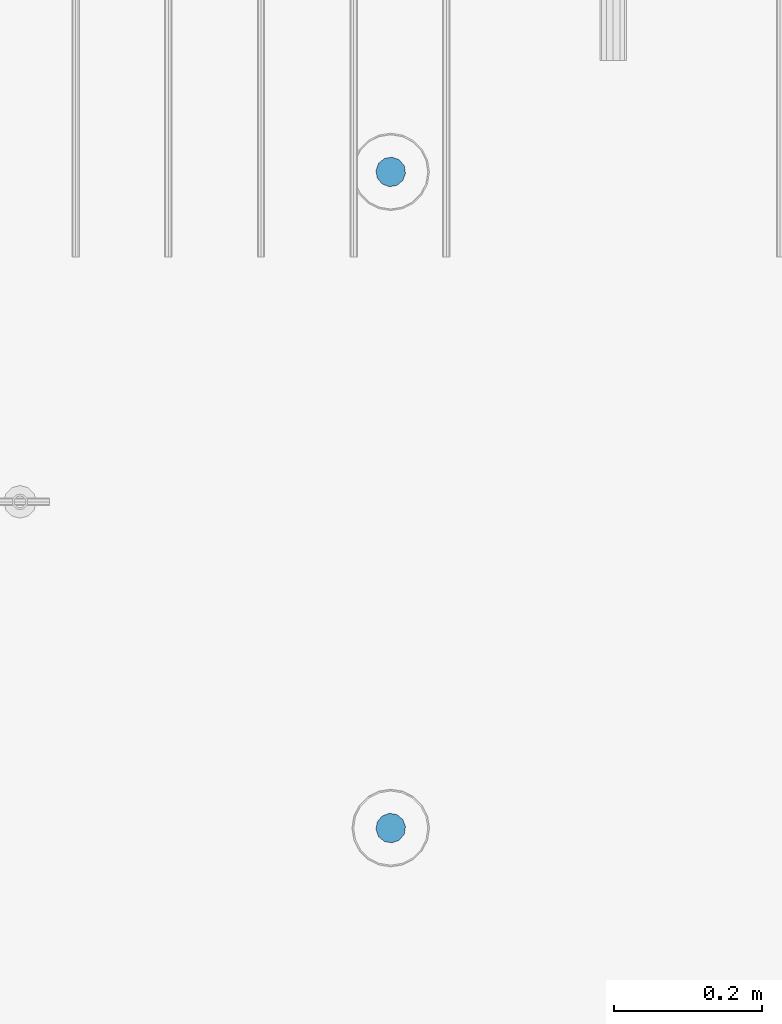
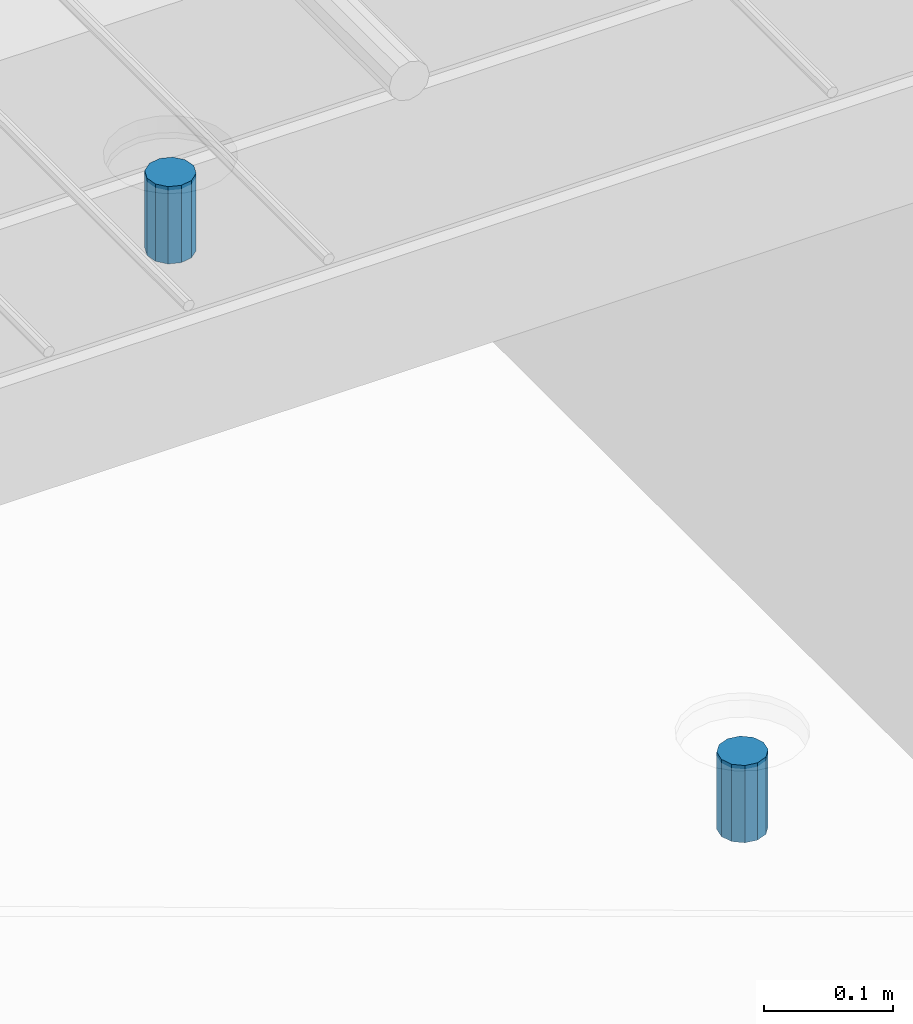
# One storey, part 50 of 350: 2 columns, 3 elements without a shape of their own.
"""IFC2X3 building model written with IfcOpenShell, lengths in millimetres."""

from ifc_helpers import new_model, si_unit, frame, origin_with_axes, place, context, subcontext, project, spatial, faceted_brep, material, type_object, element, aggregate, save


model = new_model("IFC2X3")

# Units and contexts
model_context = context("Model", 3, precision=1e-05, world=origin_with_axes())
body_context = subcontext(model_context, "Body", "Model", "MODEL_VIEW")
ifc_project = project(units=[si_unit("LENGTHUNIT", "METRE", prefix="MILLI"), si_unit("AREAUNIT", "SQUARE_METRE"), si_unit("VOLUMEUNIT", "CUBIC_METRE"), si_unit("MASSUNIT", "GRAM", prefix="KILO"), si_unit("TIMEUNIT", "SECOND"), si_unit("PLANEANGLEUNIT", "RADIAN"), si_unit("SOLIDANGLEUNIT", "STERADIAN"), si_unit("THERMODYNAMICTEMPERATUREUNIT", "DEGREE_CELSIUS"), si_unit("LUMINOUSINTENSITYUNIT", "LUMEN")], contexts=[model_context])

# Site, building, storey
site_placement = place(None, origin_with_axes())
site = spatial("IfcSite", under=ifc_project, at=site_placement, CompositionType="ELEMENT")
building_placement = place(site_placement, origin_with_axes())
building = spatial("IfcBuilding", under=site, at=building_placement, CompositionType="ELEMENT")
storey_placement = place(building_placement, origin_with_axes())
storey = spatial("IfcBuildingStorey", under=building, at=storey_placement, Name="2", CompositionType="ELEMENT", Elevation=0.0)

# Assemblies, columns
assembly_1_placement = place(storey_placement, origin_with_axes())
assembly_1 = element("IfcElementAssembly", 1, at=assembly_1_placement, inside=storey, AssemblyPlace="NOTDEFINED", PredefinedType="REINFORCEMENT_UNIT")
assembly_2_placement = place(assembly_1_placement, origin_with_axes())
assembly_2 = element("IfcElementAssembly", 2, at=assembly_2_placement, Name="Steel Assembly", AssemblyPlace="NOTDEFINED", PredefinedType="RIGID_FRAME")
ifc_material = material(Name="STEEL/Steel_Undefined")
column_type = type_object("IfcColumnType", Name="D40", PredefinedType="NOTDEFINED")
column_1_placement = place(assembly_2_placement, frame((26299.9998567034, 6144.99747284471, 87625.0000000001), z_axis=(0.418944694779052, 0.908011752521126, 0.0), x_axis=(0.0, 0.0, 1.0)))
column_1 = element("IfcColumn", 3, at=column_1_placement, type_object=column_type, material=ifc_material, Name="R-Group R", ObjectType="D40", context=body_context, shape_type="Brep", body=[
    faceted_brep([(0.0, -20.0, 0.0), (0.0, -17.3205080756888, -10.0), (73.0, -17.3205080756852, -9.99999999999636), (73.0, -19.9999999999964, 3.63797880709171e-12), (0.0, -10.0, -17.3205080756888), (73.0, -10.0, -17.3205080756834), (0.0, 0.0, -20.0), (73.0, 3.63797880709171e-12, -19.9999999999964), (0.0, 10.0, -17.3205080756888), (73.0, 10.0000000000036, -17.3205080756834), (0.0, 17.3205080756888, -10.0), (73.0, 17.3205080756925, -9.99999999999818), (0.0, 20.0, 0.0), (73.0, 20.0, 3.63797880709171e-12), (0.0, 17.3205080756888, 10.0), (73.0, 17.3205080756888, 10.0000000000036), (0.0, 10.0, 17.3205080756888), (73.0, 10.0000000000036, 17.3205080756961), (0.0, 0.0, 20.0), (73.0, 3.63797880709171e-12, 20.0000000000036), (0.0, -10.0, 17.3205080756888), (73.0, -9.99999999999636, 17.3205080756925), (0.0, -17.3205080756888, 10.0), (73.0, -17.3205080756852, 10.0000000000055)], [[[0, 1, 2, 3]], [[1, 4, 5, 2]], [[4, 6, 7, 5]], [[6, 8, 9, 7]], [[8, 10, 11, 9]], [[10, 12, 13, 11]], [[12, 14, 15, 13]], [[14, 16, 17, 15]], [[16, 18, 19, 17]], [[18, 20, 21, 19]], [[20, 22, 23, 21]], [[22, 0, 3, 23]], [[5, 7, 9, 11, 13, 15, 17, 19, 21, 23, 3, 2]], [[22, 20, 18, 16, 14, 12, 10, 8, 6, 4, 1, 0]]]),
])
aggregate(assembly_2, [column_1])
assembly_3_placement = place(assembly_1_placement, origin_with_axes())
assembly_3 = element("IfcElementAssembly", 4, at=assembly_3_placement, Name="Steel Assembly", AssemblyPlace="NOTDEFINED", PredefinedType="RIGID_FRAME")
aggregate(assembly_1, [assembly_2, assembly_3])
column_2_placement = place(assembly_3_placement, frame((26299.9998565901, 7029.99930401105, 87634.9999999997), z_axis=(-0.418944694779052, 0.908011752521126, 0.0), x_axis=(0.0, 0.0, 1.0)))
column_2 = element("IfcColumn", 5, at=column_2_placement, type_object=column_type, material=ifc_material, Name="R-Group R", ObjectType="D40", context=body_context, shape_type="Brep", body=[
    faceted_brep([(0.0, -20.0, 0.0), (0.0, -17.3205080756888, -10.0), (73.0, -17.3205080756852, -9.99999999999636), (73.0, -19.9999999999964, 3.63797880709171e-12), (0.0, -10.0, -17.3205080756888), (73.0, -10.0, -17.3205080756834), (0.0, 0.0, -20.0), (73.0, 3.63797880709171e-12, -19.9999999999964), (0.0, 10.0, -17.3205080756888), (73.0, 10.0000000000036, -17.3205080756834), (0.0, 17.3205080756888, -10.0), (73.0, 17.3205080756925, -9.99999999999818), (0.0, 20.0, 0.0), (73.0, 20.0, 3.63797880709171e-12), (0.0, 17.3205080756888, 10.0), (73.0, 17.3205080756888, 10.0000000000036), (0.0, 10.0, 17.3205080756888), (73.0, 10.0000000000036, 17.3205080756961), (0.0, 0.0, 20.0), (73.0, 3.63797880709171e-12, 20.0000000000036), (0.0, -10.0, 17.3205080756888), (73.0, -9.99999999999636, 17.3205080756925), (0.0, -17.3205080756888, 10.0), (73.0, -17.3205080756852, 10.0000000000055)], [[[0, 1, 2, 3]], [[1, 4, 5, 2]], [[4, 6, 7, 5]], [[6, 8, 9, 7]], [[8, 10, 11, 9]], [[10, 12, 13, 11]], [[12, 14, 15, 13]], [[14, 16, 17, 15]], [[16, 18, 19, 17]], [[18, 20, 21, 19]], [[20, 22, 23, 21]], [[22, 0, 3, 23]], [[5, 7, 9, 11, 13, 15, 17, 19, 21, 23, 3, 2]], [[22, 20, 18, 16, 14, 12, 10, 8, 6, 4, 1, 0]]]),
])
aggregate(assembly_3, [column_2])

save(model, "model.ifc")
